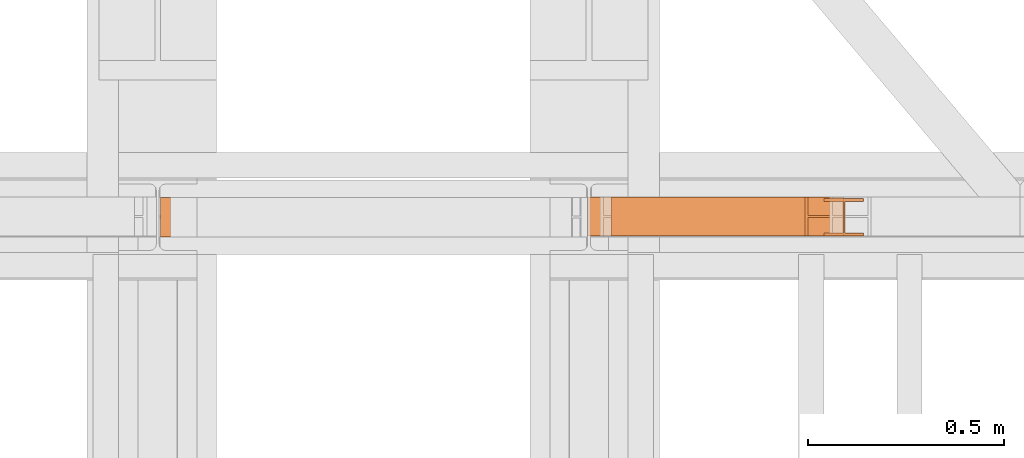
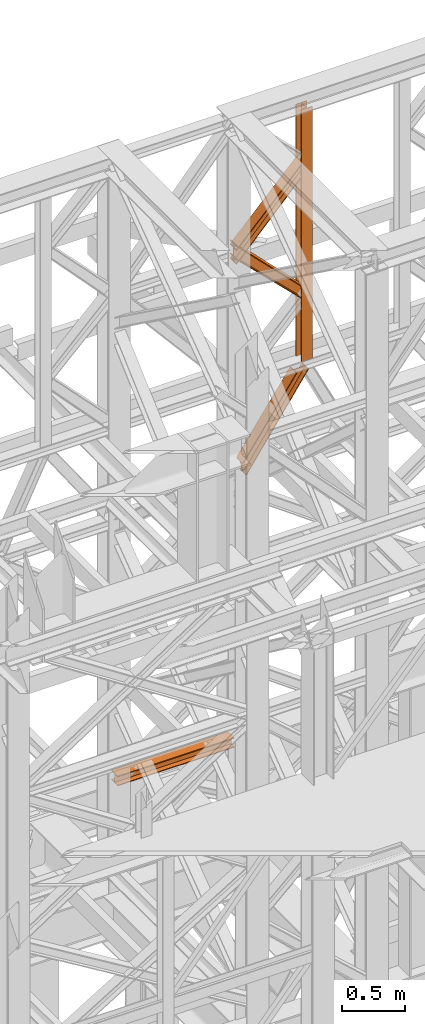
# One storey, part 174 of 208: 5 proxies.
"""IFC2X3 building model written with IfcOpenShell, lengths in millimetres."""

from ifc_helpers import new_model, entity, si_unit, converted_unit, frame, origin, origin_with_axes, place, context, subcontext, project, spatial, faceted_brep, element, save


model = new_model("IFC2X3")

# Units and contexts
model_context = context("Model", 3, precision=1e-05, world=origin())
plan_context = context("Plan", 3, precision=1e-05, world=origin())
body_context = subcontext(model_context, "Body", "Model", "MODEL_VIEW")
ifc_project = project(units=[si_unit("LENGTHUNIT", "METRE", prefix="MILLI"), converted_unit("PLANEANGLEUNIT", "DEGREE", entity("IfcPlaneAngleMeasure", 0.0174532925199433), si_unit("PLANEANGLEUNIT", "RADIAN"), dimensions=[0, 0, 0, 0, 0, 0, 0]), si_unit("AREAUNIT", "SQUARE_METRE"), si_unit("VOLUMEUNIT", "CUBIC_METRE")], contexts=[model_context, plan_context])

# Building, storey
building_placement = place(None, origin())
building = spatial("IfcBuilding", under=ifc_project, at=building_placement, CompositionType="COMPLEX")
storey_placement = place(building_placement, origin_with_axes())
storey = spatial("IfcBuildingStorey", under=building, at=storey_placement, Name="Geschoss", CompositionType="ELEMENT")

# Proxies
proxy_1_placement = place(storey_placement, frame((7193.254968528663, -13810.57439404318, 9798.105713222345), z_axis=(0.0, 0.0, 1.0), x_axis=(1.0, 0.0, 0.0)))
element("IfcBuildingElementProxy", 1, at=proxy_1_placement, inside=storey, context=body_context, shape_type="Brep", body=[
    faceted_brep([(100.0100000000039, 88.01000000000022, 0.01000000000021828), (100.0100000000039, 96.01000000000022, 0.01000000000021828), (0.01000000000385626, 96.01000000000022, 0.01000000000021828), (0.01000000000385626, 88.01000000000022, 0.01000000000021828), (47.51000000000386, 88.01000000000022, 0.01000000000021828), (47.51000000000386, 8.010000000000218, 0.01000000000021828), (0.01000000000385626, 8.010000000000218, 0.01000000000021828), (0.01000000000385626, 0.01000000000021828, 0.01000000000021828), (100.0100000000039, 0.01000000000021828, 0.01000000000021828), (100.0100000000039, 8.010000000000218, 0.01000000000021828), (52.51000000000386, 8.010000000000218, 0.01000000000021828), (52.51000000000386, 88.01000000000022, 0.01000000000021828), (100.0100000000039, 96.01000000000022, 0.01000000000021828), (100.0100000000039, 88.01000000000022, 0.01000000000021828), (100.0100000000002, 88.01000000000022, 2451.894345471463), (100.0100000000002, 96.01000000000022, 2451.894345471463), (0.01000000000385626, 96.01000000000022, 0.01000000000021828), (100.0100000000039, 96.01000000000022, 0.01000000000021828), (100.0100000000002, 96.01000000000022, 2451.894345471463), (0.01000000000021828, 96.01000000000022, 2451.894345471463), (0.01000000000385626, 88.01000000000022, 0.01000000000021828), (0.01000000000385626, 96.01000000000022, 0.01000000000021828), (0.01000000000021828, 96.01000000000022, 2451.894345471463), (0.01000000000021828, 88.01000000000022, 2451.894345471463), (47.51000000000386, 88.01000000000022, 0.01000000000021828), (0.01000000000385626, 88.01000000000022, 0.01000000000021828), (0.01000000000021828, 88.01000000000022, 2451.894345471463), (47.51000000000022, 88.01000000000022, 2451.894345471463), (47.51000000000386, 8.010000000000218, 0.01000000000021828), (47.51000000000386, 88.01000000000022, 0.01000000000021828), (47.51000000000022, 88.01000000000022, 2451.894345471463), (47.51000000000022, 8.010000000000218, 2451.894345471463), (0.01000000000385626, 8.010000000000218, 0.01000000000021828), (47.51000000000386, 8.010000000000218, 0.01000000000021828), (47.51000000000022, 8.010000000000218, 2451.894345471463), (0.01000000000021828, 8.010000000000218, 2451.894345471463), (0.01000000000385626, 0.01000000000021828, 0.01000000000021828), (0.01000000000385626, 8.010000000000218, 0.01000000000021828), (0.01000000000021828, 8.010000000000218, 2451.894345471463), (0.01000000000021828, 0.01000000000021828, 2451.894345471463), (100.0100000000039, 0.01000000000021828, 0.01000000000021828), (0.01000000000385626, 0.01000000000021828, 0.01000000000021828), (0.01000000000021828, 0.01000000000021828, 2451.894345471463), (100.0100000000002, 0.01000000000021828, 2451.894345471463), (100.0100000000039, 8.010000000000218, 0.01000000000021828), (100.0100000000039, 0.01000000000021828, 0.01000000000021828), (100.0100000000002, 0.01000000000021828, 2451.894345471463), (100.0100000000002, 8.010000000000218, 2451.894345471463), (52.51000000000386, 8.010000000000218, 0.01000000000021828), (100.0100000000039, 8.010000000000218, 0.01000000000021828), (100.0100000000002, 8.010000000000218, 2451.894345471463), (52.51000000000022, 8.010000000000218, 2451.894345471463), (52.51000000000386, 88.01000000000022, 0.01000000000021828), (52.51000000000386, 8.010000000000218, 0.01000000000021828), (52.51000000000022, 8.010000000000218, 2451.894345471463), (52.51000000000022, 88.01000000000022, 2451.894345471463), (100.0100000000039, 88.01000000000022, 0.01000000000021828), (52.51000000000386, 88.01000000000022, 0.01000000000021828), (52.51000000000022, 88.01000000000022, 2451.894345471463), (100.0100000000002, 88.01000000000022, 2451.894345471463), (100.0100000000002, 88.01000000000022, 2451.894345471463), (52.51000000000022, 88.01000000000022, 2451.894345471463), (52.51000000000022, 8.010000000000218, 2451.894345471463), (100.0100000000002, 8.010000000000218, 2451.894345471463), (100.0100000000002, 0.01000000000021828, 2451.894345471463), (0.01000000000021828, 0.01000000000021828, 2451.894345471463), (0.01000000000021828, 8.010000000000218, 2451.894345471463), (47.51000000000022, 8.010000000000218, 2451.894345471463), (47.51000000000022, 88.01000000000022, 2451.894345471463), (0.01000000000021828, 88.01000000000022, 2451.894345471463), (0.01000000000021828, 96.01000000000022, 2451.894345471463), (100.0100000000002, 96.01000000000022, 2451.894345471463)], [[[0, 1, 2, 3, 4, 5, 6, 7, 8, 9, 10, 11]], [[12, 13, 14, 15]], [[16, 17, 18, 19]], [[20, 21, 22, 23]], [[24, 25, 26, 27]], [[28, 29, 30, 31]], [[32, 33, 34, 35]], [[36, 37, 38, 39]], [[40, 41, 42, 43]], [[44, 45, 46, 47]], [[48, 49, 50, 51]], [[52, 53, 54, 55]], [[56, 57, 58, 59]], [[60, 61, 62, 63, 64, 65, 66, 67, 68, 69, 70, 71]]], orient=[[False], [False], [False], [False], [False], [False], [False], [False], [False], [False], [False], [False], [False], [False]]),
])
proxy_2_placement = place(storey_placement, frame((6593.254967038549, -13810.57439404318, 10955.2185593949), z_axis=(0.0, 0.0, 1.0), x_axis=(1.0, 0.0, 0.0)))
element("IfcBuildingElementProxy", 2, at=proxy_2_placement, inside=storey, context=body_context, shape_type="Brep", body=[
    faceted_brep([(0.01000000000021828, 0.01000000000203727, 136.1559367639657), (0.01000000000021828, 0.01000000000021828, 145.6651963377171), (647.5100014901163, 0.01000000000021828, 821.3321792650186), (647.5100014901163, 0.01000000000021828, 810.8787261814559), (0.01000000000021828, 0.01000000000021828, 145.6651963377171), (0.01000000000203727, 100.0100000000002, 145.6651963377208), (647.5100014901172, 100.0100000000002, 821.3321792650258), (647.5100014901163, 0.01000000000021828, 821.3321792650186), (0.01000000000203727, 100.0100000000002, 145.6651963377208), (0.01000000000021828, 100.0100000000002, 136.1559367639657), (647.5100014901163, 100.0100000000002, 810.8787261814559), (647.5100014901172, 100.0100000000002, 821.3321792650258), (0.01000000000021828, 100.0100000000002, 136.1559367639657), (0.01000000000385626, 52.51000000000022, 136.1559367639693), (647.5100014901163, 52.51000000000022, 810.8787261814559), (647.5100014901163, 100.0100000000002, 810.8787261814559), (0.01000000000385626, 52.51000000000022, 136.1559367639693), (0.01000000000021828, 52.51000000000022, 9.52026454738916), (647.5100014901172, 52.51000000000022, 700.4756203415545), (647.5100014901163, 52.51000000000022, 810.8787261814559), (0.01000000000021828, 52.51000000000022, 9.52026454738916), (0.009999999999308784, 100.0100000000002, 9.520264547385523), (647.51000149012, 100.0100000000002, 700.4756203415545), (647.5100014901172, 52.51000000000022, 700.4756203415545), (0.009999999999308784, 100.0100000000002, 9.520264547385523), (0.01000000000021828, 100.0100000000002, 0.01000000000021828), (647.5100014901163, 100.0100000000002, 690.0159394275852), (647.51000149012, 100.0100000000002, 700.4756203415545), (0.01000000000021828, 100.0100000000002, 0.01000000000021828), (0.01000000000112777, 0.01000000000021828, 0.01000000000021828), (647.5100014901172, 0.01000000000021828, 690.0159394275852), (647.5100014901163, 100.0100000000002, 690.0159394275852), (0.01000000000112777, 0.01000000000021828, 0.01000000000021828), (0.01000000000021828, 0.01000000000021828, 9.520264547392799), (647.5100014901163, 0.01000000000021828, 700.4756203415545), (647.5100014901172, 0.01000000000021828, 690.0159394275852), (0.01000000000021828, 0.01000000000021828, 9.520264547392799), (0.009999999999308784, 47.51000000000022, 9.520264547392799), (647.5100014901182, 47.51000000000022, 700.4756203415545), (647.5100014901163, 0.01000000000021828, 700.4756203415545), (0.009999999999308784, 47.51000000000022, 9.520264547392799), (0.01000000000021828, 47.51000000000022, 136.1559367639657), (647.5100014901163, 47.51000000000022, 810.8787261814559), (647.5100014901182, 47.51000000000022, 700.4756203415545), (0.01000000000021828, 47.51000000000022, 136.1559367639657), (0.01000000000021828, 0.01000000000203727, 136.1559367639657), (647.5100014901163, 0.01000000000021828, 810.8787261814559), (647.5100014901163, 47.51000000000022, 810.8787261814559), (647.5100014901163, 0.01000000000021828, 810.8787261814559), (647.5100014901163, 0.01000000000021828, 821.3321792650186), (647.5100014901172, 100.0100000000002, 821.3321792650258), (647.5100014901163, 100.0100000000002, 810.8787261814559), (647.5100014901163, 52.51000000000022, 810.8787261814559), (647.5100014901172, 52.51000000000022, 700.4756203415545), (647.51000149012, 100.0100000000002, 700.4756203415545), (647.5100014901163, 100.0100000000002, 690.0159394275852), (647.5100014901172, 0.01000000000021828, 690.0159394275852), (647.5100014901163, 0.01000000000021828, 700.4756203415545), (647.5100014901182, 47.51000000000022, 700.4756203415545), (647.5100014901163, 47.51000000000022, 810.8787261814559), (0.01000000000021828, 0.01000000000021828, 145.6651963377171), (0.01000000000021828, 0.01000000000203727, 136.1559367639657), (0.01000000000021828, 47.51000000000022, 136.1559367639657), (0.009999999999308784, 47.51000000000022, 9.520264547392799), (0.01000000000021828, 0.01000000000021828, 9.520264547392799), (0.01000000000112777, 0.01000000000021828, 0.01000000000021828), (0.01000000000021828, 100.0100000000002, 0.01000000000021828), (0.009999999999308784, 100.0100000000002, 9.520264547385523), (0.01000000000021828, 52.51000000000022, 9.52026454738916), (0.01000000000385626, 52.51000000000022, 136.1559367639693), (0.01000000000021828, 100.0100000000002, 136.1559367639657), (0.01000000000203727, 100.0100000000002, 145.6651963377208)], [[[0, 1, 2, 3]], [[4, 5, 6, 7]], [[8, 9, 10, 11]], [[12, 13, 14, 15]], [[16, 17, 18, 19]], [[20, 21, 22, 23]], [[24, 25, 26, 27]], [[28, 29, 30, 31]], [[32, 33, 34, 35]], [[36, 37, 38, 39]], [[40, 41, 42, 43]], [[44, 45, 46, 47]], [[48, 49, 50, 51, 52, 53, 54, 55, 56, 57, 58, 59]], [[60, 61, 62, 63, 64, 65, 66, 67, 68, 69, 70, 71]]], orient=[[False], [False], [False], [False], [False], [False], [False], [False], [False], [False], [False], [False], [False], [False]]),
])
proxy_3_placement = place(storey_placement, frame((6590.004968461604, -13810.57439404318, 10364.55433028874), z_axis=(0.0, 0.0, 1.0), x_axis=(1.0, 0.0, 0.0)))
element("IfcBuildingElementProxy", 3, at=proxy_3_placement, inside=storey, context=body_context, shape_type="Brep", body=[
    faceted_brep([(0.01000000000658474, 0.01000000000203727, 771.736684541449), (0.01000000000658474, 0.01000000000021828, 780.9755634240846), (653.2600000670636, 0.01000000000021828, 127.2232754441011), (653.2600000670636, 0.01000000000021828, 117.0703501202133), (0.01000000000658474, 0.01000000000021828, 780.9755634240846), (0.01000000000567525, 100.0100000000002, 780.9755634240883), (653.2600000670664, 100.0100000000002, 127.2232754441011), (653.2600000670636, 0.01000000000021828, 127.2232754441011), (0.01000000000567525, 100.0100000000002, 780.9755634240883), (0.01000000000658474, 100.0100000000002, 771.7366845414454), (653.2600000670636, 100.0100000000002, 117.0703501202133), (653.2600000670664, 100.0100000000002, 127.2232754441011), (0.01000000000658474, 100.0100000000002, 771.7366845414454), (0.01000000000021828, 52.51000000000204, 771.7366845414526), (653.2600000670645, 52.51000000000022, 117.0703501202133), (653.2600000670636, 100.0100000000002, 117.0703501202133), (0.01000000000021828, 52.51000000000204, 771.7366845414526), (0.01000000000658474, 52.51000000000022, 649.4102960638211), (653.2600000670636, 52.51000000000022, 10.10333120962423), (653.2600000670645, 52.51000000000022, 117.0703501202133), (0.01000000000658474, 52.51000000000022, 649.4102960638211), (0.01000000000658474, 100.010000000002, 649.4102960638247), (653.2600000670636, 100.0100000000002, 10.10333120962787), (653.2600000670636, 52.51000000000022, 10.10333120962423), (0.01000000000658474, 100.010000000002, 649.4102960638247), (0.01000000000658474, 100.0100000000002, 640.194998598121), (653.2600000670636, 100.0100000000002, 0.01000000000385626), (653.2600000670636, 100.0100000000002, 10.10333120962787), (0.01000000000658474, 100.0100000000002, 640.194998598121), (0.01000000000658474, 0.01000000000021828, 640.194998598121), (653.2600000670636, 0.01000000000021828, 0.01000000000021828), (653.2600000670636, 100.0100000000002, 0.01000000000385626), (0.01000000000658474, 0.01000000000021828, 640.194998598121), (0.01000000000658474, 0.01000000000203727, 649.4102960638247), (653.2600000670636, 0.01000000000021828, 10.10333120962423), (653.2600000670636, 0.01000000000021828, 0.01000000000021828), (0.01000000000658474, 0.01000000000203727, 649.4102960638247), (0.01000000000658474, 47.51000000000204, 649.4102960638284), (653.2600000670636, 47.51000000000022, 10.10333120962787), (653.2600000670636, 0.01000000000021828, 10.10333120962423), (0.01000000000658474, 47.51000000000204, 649.4102960638284), (0.01000000000658474, 47.51000000000022, 771.7366845414454), (653.2600000670636, 47.51000000000022, 117.0703501202133), (653.2600000670636, 47.51000000000022, 10.10333120962787), (0.01000000000658474, 47.51000000000022, 771.7366845414454), (0.01000000000658474, 0.01000000000203727, 771.736684541449), (653.2600000670636, 0.01000000000021828, 117.0703501202133), (653.2600000670636, 47.51000000000022, 117.0703501202133), (653.2600000670636, 0.01000000000021828, 117.0703501202133), (653.2600000670636, 0.01000000000021828, 127.2232754441011), (653.2600000670664, 100.0100000000002, 127.2232754441011), (653.2600000670636, 100.0100000000002, 117.0703501202133), (653.2600000670645, 52.51000000000022, 117.0703501202133), (653.2600000670636, 52.51000000000022, 10.10333120962423), (653.2600000670636, 100.0100000000002, 10.10333120962787), (653.2600000670636, 100.0100000000002, 0.01000000000385626), (653.2600000670636, 0.01000000000021828, 0.01000000000021828), (653.2600000670636, 0.01000000000021828, 10.10333120962423), (653.2600000670636, 47.51000000000022, 10.10333120962787), (653.2600000670636, 47.51000000000022, 117.0703501202133), (0.01000000000658474, 0.01000000000021828, 780.9755634240846), (0.01000000000658474, 0.01000000000203727, 771.736684541449), (0.01000000000658474, 47.51000000000022, 771.7366845414454), (0.01000000000658474, 47.51000000000204, 649.4102960638284), (0.01000000000658474, 0.01000000000203727, 649.4102960638247), (0.01000000000658474, 0.01000000000021828, 640.194998598121), (0.01000000000658474, 100.0100000000002, 640.194998598121), (0.01000000000658474, 100.010000000002, 649.4102960638247), (0.01000000000658474, 52.51000000000022, 649.4102960638211), (0.01000000000021828, 52.51000000000204, 771.7366845414526), (0.01000000000658474, 100.0100000000002, 771.7366845414454), (0.01000000000567525, 100.0100000000002, 780.9755634240883)], [[[0, 1, 2, 3]], [[4, 5, 6, 7]], [[8, 9, 10, 11]], [[12, 13, 14, 15]], [[16, 17, 18, 19]], [[20, 21, 22, 23]], [[24, 25, 26, 27]], [[28, 29, 30, 31]], [[32, 33, 34, 35]], [[36, 37, 38, 39]], [[40, 41, 42, 43]], [[44, 45, 46, 47]], [[48, 49, 50, 51, 52, 53, 54, 55, 56, 57, 58, 59]], [[60, 61, 62, 63, 64, 65, 66, 67, 68, 69, 70, 71]]], orient=[[False], [False], [False], [False], [False], [False], [False], [False], [False], [False], [False], [False], [False], [False]]),
])
proxy_4_placement = place(storey_placement, frame((6650.592727804952, -13810.57439404318, 8872.310477686953), z_axis=(0.0, 0.0, 1.0), x_axis=(1.0, 0.0, 0.0)))
element("IfcBuildingElementProxy", 4, at=proxy_4_placement, inside=storey, context=body_context, shape_type="Brep", body=[
    faceted_brep([(2.129900098893813, 0.01000000000021828, 123.6259631817866), (0.009999999999308784, 0.01000000000021828, 131.7181462696044), (493.3676242930878, 0.01000000000021828, 837.8052355353921), (501.7261570972341, 0.01000000000021828, 837.8052355353921), (0.009999999999308784, 0.01000000000021828, 131.7181462696044), (0.009999999999308784, 100.0100000000002, 131.7181462696044), (493.3676242930906, 100.0100000000002, 837.8052355353921), (493.3676242930878, 0.01000000000021828, 837.8052355353921), (0.009999999999308784, 100.0100000000002, 131.7181462696044), (2.129900098893813, 100.0100000000002, 123.6259631817866), (501.7261570972341, 100.0100000000002, 837.8052355353921), (493.3676242930906, 100.0100000000002, 837.8052355353921), (2.129900098893813, 100.0100000000002, 123.6259631817866), (2.129900098893813, 52.51000000000022, 123.6259631817866), (501.7261570972369, 52.51000000000022, 837.8052355353921), (501.7261570972341, 100.0100000000002, 837.8052355353921), (2.129900098893813, 52.51000000000022, 123.6259631817866), (32.39392087263059, 52.51000000000022, 8.100709325468415), (601.3553964383018, 52.51000000000022, 837.8052355353921), (501.7261570972369, 52.51000000000022, 837.8052355353921), (32.39392087263059, 52.51000000000022, 8.100709325468415), (32.39392087262877, 100.0100000000002, 8.100709325472053), (601.3553964382982, 100.0100000000002, 837.8052355353921), (601.3553964383018, 52.51000000000022, 837.8052355353921), (32.39392087262877, 100.0100000000002, 8.100709325472053), (34.5134348916572, 100.0100000000002, 0.01000000000021828), (609.691863800369, 100.0100000000002, 837.8052355353921), (601.3553964382982, 100.0100000000002, 837.8052355353921), (34.5134348916572, 100.0100000000002, 0.01000000000021828), (34.51343489165902, 0.01000000000021828, 0.01000000000021828), (609.6918638003699, 0.01000000000021828, 837.8052355353921), (609.691863800369, 100.0100000000002, 837.8052355353921), (34.51343489165902, 0.01000000000021828, 0.01000000000021828), (32.39392087262877, 0.01000000000021828, 8.100709325472053), (601.3553964382954, 0.01000000000021828, 837.8052355353921), (609.6918638003699, 0.01000000000021828, 837.8052355353921), (32.39392087262877, 0.01000000000021828, 8.100709325472053), (32.39392087262877, 47.51000000000022, 8.100709325475691), (601.3553964382963, 47.51000000000022, 837.8052355353884), (601.3553964382954, 0.01000000000021828, 837.8052355353921), (32.39392087262877, 47.51000000000022, 8.100709325475691), (2.129900098893813, 47.51000000000022, 123.6259631817866), (501.7261570972341, 47.51000000000022, 837.8052355353921), (601.3553964382963, 47.51000000000022, 837.8052355353884), (2.129900098893813, 47.51000000000022, 123.6259631817866), (2.129900098893813, 0.01000000000021828, 123.6259631817866), (501.7261570972341, 0.01000000000021828, 837.8052355353921), (501.7261570972341, 47.51000000000022, 837.8052355353921), (0.009999999999308784, 0.01000000000021828, 131.7181462696044), (2.129900098893813, 0.01000000000021828, 123.6259631817866), (2.129900098893813, 47.51000000000022, 123.6259631817866), (32.39392087262877, 47.51000000000022, 8.100709325475691), (32.39392087262877, 0.01000000000021828, 8.100709325472053), (34.51343489165902, 0.01000000000021828, 0.01000000000021828), (34.5134348916572, 100.0100000000002, 0.01000000000021828), (32.39392087262877, 100.0100000000002, 8.100709325472053), (32.39392087263059, 52.51000000000022, 8.100709325468415), (2.129900098893813, 52.51000000000022, 123.6259631817866), (2.129900098893813, 100.0100000000002, 123.6259631817866), (0.009999999999308784, 100.0100000000002, 131.7181462696044), (501.7261570972341, 0.01000000000021828, 837.8052355353921), (493.3676242930878, 0.01000000000021828, 837.8052355353921), (493.3676242930906, 100.0100000000002, 837.8052355353921), (501.7261570972341, 100.0100000000002, 837.8052355353921), (501.7261570972369, 52.51000000000022, 837.8052355353921), (601.3553964383018, 52.51000000000022, 837.8052355353921), (601.3553964382982, 100.0100000000002, 837.8052355353921), (609.691863800369, 100.0100000000002, 837.8052355353921), (609.6918638003699, 0.01000000000021828, 837.8052355353921), (601.3553964382954, 0.01000000000021828, 837.8052355353921), (601.3553964382963, 47.51000000000022, 837.8052355353884), (501.7261570972341, 47.51000000000022, 837.8052355353921)], [[[0, 1, 2, 3]], [[4, 5, 6, 7]], [[8, 9, 10, 11]], [[12, 13, 14, 15]], [[16, 17, 18, 19]], [[20, 21, 22, 23]], [[24, 25, 26, 27]], [[28, 29, 30, 31]], [[32, 33, 34, 35]], [[36, 37, 38, 39]], [[40, 41, 42, 43]], [[44, 45, 46, 47]], [[48, 49, 50, 51, 52, 53, 54, 55, 56, 57, 58, 59]], [[60, 61, 62, 63, 64, 65, 66, 67, 68, 69, 70, 71]]], orient=[[False], [False], [False], [False], [False], [False], [False], [False], [False], [False], [False], [False], [False], [False]]),
])
proxy_5_placement = place(storey_placement, frame((5500.423030329277, -13812.50587051042, 6270.660956017005), z_axis=(0.0, 0.0, 1.0), x_axis=(1.0, 0.0, 0.0)))
element("IfcBuildingElementProxy", 5, at=proxy_5_placement, inside=storey, context=body_context, shape_type="Brep", body=[
    faceted_brep([(1072.594465339767, 0.01000000000021828, 88.01000000000022), (1072.594465339767, 0.01000000000021828, 96.01000000000022), (1072.594465339767, 100.0100000000002, 96.01000000000022), (1072.594465339767, 100.0100000000002, 88.01000000000022), (1072.594465339767, 52.51000000000022, 88.01000000000022), (1072.594465339767, 52.51000000000022, 8.010000000000218), (1072.594465339767, 100.0100000000002, 8.010000000000218), (1072.594465339767, 100.0100000000002, 0.01000000000021828), (1072.594465339767, 0.01000000000021828, 0.01000000000021828), (1072.594465339767, 0.01000000000021828, 8.010000000000218), (1072.594465339767, 47.51000000000022, 8.010000000000218), (1072.594465339767, 47.51000000000022, 88.01000000000022), (1072.594465339767, 0.01000000000021828, 96.01000000000022), (1072.594465339767, 0.01000000000021828, 88.01000000000022), (0.01000000000021828, 0.01000000000385626, 88.01000000000022), (0.01000000000021828, 0.01000000000385626, 96.01000000000022), (1072.594465339767, 100.0100000000002, 96.01000000000022), (1072.594465339767, 0.01000000000021828, 96.01000000000022), (0.01000000000021828, 0.01000000000385626, 96.01000000000022), (0.01000000000021828, 100.0100000000039, 96.01000000000022), (1072.594465339767, 100.0100000000002, 88.01000000000022), (1072.594465339767, 100.0100000000002, 96.01000000000022), (0.01000000000021828, 100.0100000000039, 96.01000000000022), (0.01000000000021828, 100.0100000000039, 88.01000000000022), (1072.594465339767, 52.51000000000022, 88.01000000000022), (1072.594465339767, 100.0100000000002, 88.01000000000022), (0.01000000000021828, 100.0100000000039, 88.01000000000022), (0.01000000000021828, 52.51000000000386, 88.01000000000022), (1072.594465339767, 52.51000000000022, 8.010000000000218), (1072.594465339767, 52.51000000000022, 88.01000000000022), (0.01000000000021828, 52.51000000000386, 88.01000000000022), (0.01000000000021828, 52.51000000000386, 8.010000000000218), (1072.594465339767, 100.0100000000002, 8.010000000000218), (1072.594465339767, 52.51000000000022, 8.010000000000218), (0.01000000000021828, 52.51000000000386, 8.010000000000218), (0.01000000000021828, 100.0100000000039, 8.010000000000218), (1072.594465339767, 100.0100000000002, 0.01000000000021828), (1072.594465339767, 100.0100000000002, 8.010000000000218), (0.01000000000021828, 100.0100000000039, 8.010000000000218), (0.01000000000021828, 100.0100000000039, 0.01000000000021828), (1072.594465339767, 0.01000000000021828, 0.01000000000021828), (1072.594465339767, 100.0100000000002, 0.01000000000021828), (0.01000000000021828, 100.0100000000039, 0.01000000000021828), (0.01000000000021828, 0.01000000000385626, 0.01000000000021828), (1072.594465339767, 0.01000000000021828, 8.010000000000218), (1072.594465339767, 0.01000000000021828, 0.01000000000021828), (0.01000000000021828, 0.01000000000385626, 0.01000000000021828), (0.01000000000021828, 0.01000000000385626, 8.010000000000218), (1072.594465339767, 47.51000000000022, 8.010000000000218), (1072.594465339767, 0.01000000000021828, 8.010000000000218), (0.01000000000021828, 0.01000000000385626, 8.010000000000218), (0.01000000000021828, 47.51000000000386, 8.010000000000218), (1072.594465339767, 47.51000000000022, 88.01000000000022), (1072.594465339767, 47.51000000000022, 8.010000000000218), (0.01000000000021828, 47.51000000000386, 8.010000000000218), (0.01000000000021828, 47.51000000000386, 88.01000000000022), (1072.594465339767, 0.01000000000021828, 88.01000000000022), (1072.594465339767, 47.51000000000022, 88.01000000000022), (0.01000000000021828, 47.51000000000386, 88.01000000000022), (0.01000000000021828, 0.01000000000385626, 88.01000000000022), (0.01000000000021828, 0.01000000000385626, 88.01000000000022), (0.01000000000021828, 47.51000000000386, 88.01000000000022), (0.01000000000021828, 47.51000000000386, 8.010000000000218), (0.01000000000021828, 0.01000000000385626, 8.010000000000218), (0.01000000000021828, 0.01000000000385626, 0.01000000000021828), (0.01000000000021828, 100.0100000000039, 0.01000000000021828), (0.01000000000021828, 100.0100000000039, 8.010000000000218), (0.01000000000021828, 52.51000000000386, 8.010000000000218), (0.01000000000021828, 52.51000000000386, 88.01000000000022), (0.01000000000021828, 100.0100000000039, 88.01000000000022), (0.01000000000021828, 100.0100000000039, 96.01000000000022), (0.01000000000021828, 0.01000000000385626, 96.01000000000022)], [[[0, 1, 2, 3, 4, 5, 6, 7, 8, 9, 10, 11]], [[12, 13, 14, 15]], [[16, 17, 18, 19]], [[20, 21, 22, 23]], [[24, 25, 26, 27]], [[28, 29, 30, 31]], [[32, 33, 34, 35]], [[36, 37, 38, 39]], [[40, 41, 42, 43]], [[44, 45, 46, 47]], [[48, 49, 50, 51]], [[52, 53, 54, 55]], [[56, 57, 58, 59]], [[60, 61, 62, 63, 64, 65, 66, 67, 68, 69, 70, 71]]], orient=[[False], [False], [False], [False], [False], [False], [False], [False], [False], [False], [False], [False], [False], [False]]),
])

save(model, "model.ifc")
